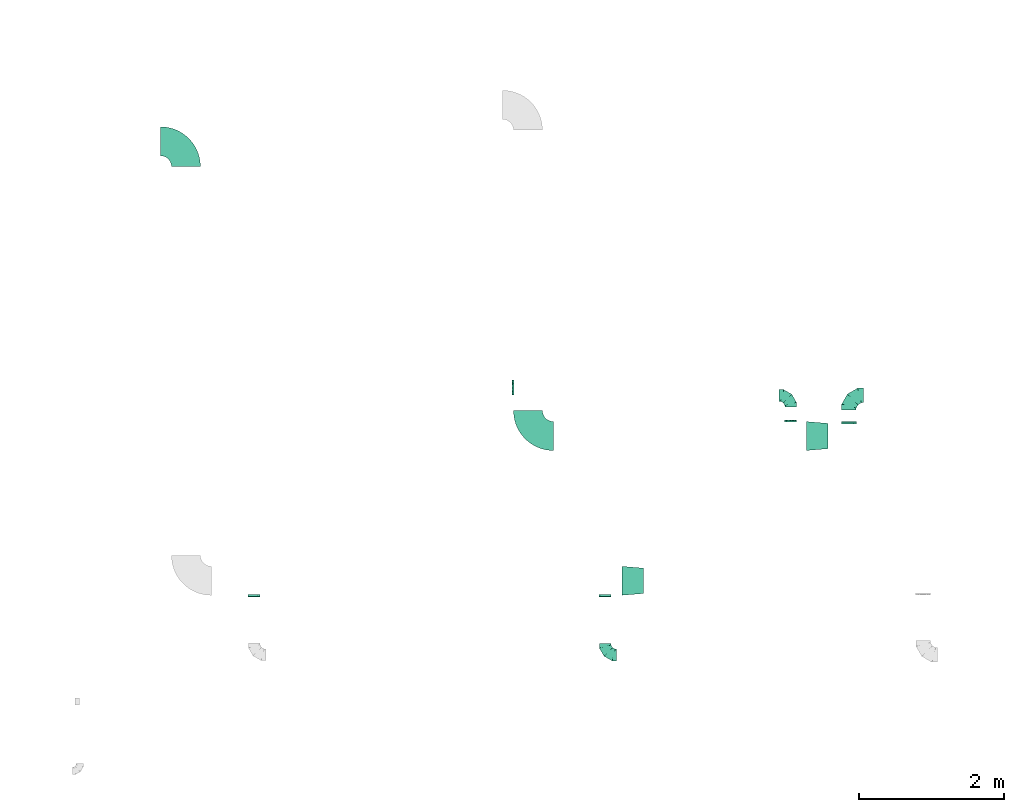
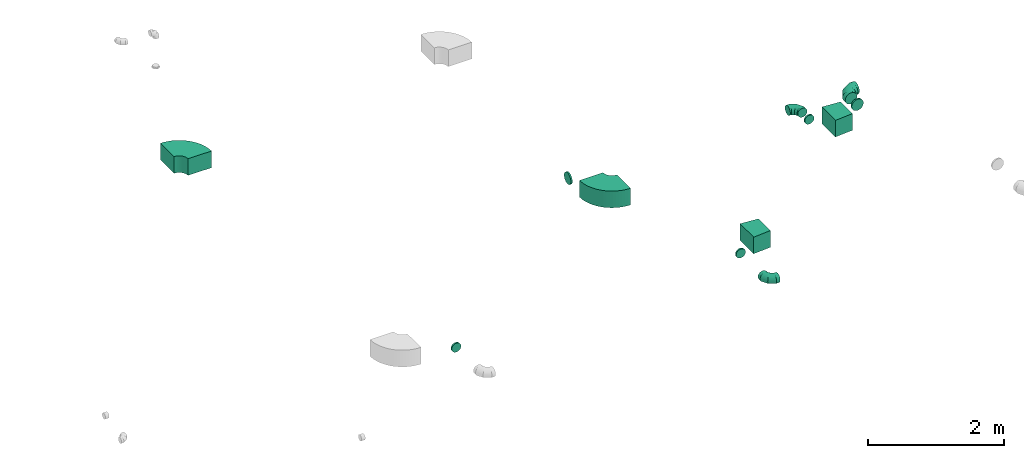
# One storey, part 15 of 32: 12 flow fittings.
"""IFC2X3 building model written with IfcOpenShell, lengths in millimetres."""

import ifcopenshell
import ifcopenshell.guid

model = None  # the IFC model being written
_history = None  # IfcOwnerHistory: only IFC2X3 demands one
_inside = {}  # id of a spatial element -> (the spatial element, [elements in it])
_under = {}  # id of a project, library or spatial element -> (it, [spatial elements below it])
_declared = {}  # id of a project -> (the project, [libraries it declares])
_typed = {}  # id of a type object -> (the type object, [elements of that type])
_made_of = {}  # id of a material, layer set ... -> (it, [elements and type objects made of it])


def new_model(schema):
    """Start an empty IFC model of exactly this schema.

    Asked for "IFC4X3", IfcOpenShell would pick the latest addendum, in which some entities
    have other attributes; the version numbers below select the first issue.
    IFC2X3 requires an IfcOwnerHistory on every rooted entity: one is made here for all.
    """
    global model, _history
    if schema == "IFC4X3":
        model = ifcopenshell.file(schema_version=(4, 3, 0, 0))
    else:
        model = ifcopenshell.file(schema=schema)
    _inside.clear()
    _under.clear()
    _declared.clear()
    _typed.clear()
    _made_of.clear()
    _history = None
    if model.schema == "IFC2X3":
        org = make("IfcOrganization", Name="unknown")
        user = make(
            "IfcPersonAndOrganization",
            ThePerson=make("IfcPerson", FamilyName="unknown"),
            TheOrganization=org,
        )
        app = make(
            "IfcApplication",
            ApplicationDeveloper=org,
            Version="unknown",
            ApplicationFullName="unknown",
            ApplicationIdentifier="unknown",
        )
        _history = make(
            "IfcOwnerHistory",
            OwningUser=user,
            OwningApplication=app,
            ChangeAction="ADDED",
            CreationDate=0,
        )
    return model


def make(cls, **values):
    """One entity of the class cls with the attributes given. An attribute that is None is left unset."""
    return model.create_entity(
        cls, **{name: value for name, value in values.items() if value is not None}
    )


def entity(cls, *values):
    """Any entity or typed value of the class cls, its attributes in the order of the schema. None: left unset."""
    e = model.create_entity(cls)
    for i, value in enumerate(values):
        if value is not None:
            e[i] = value
    return e


def rooted(cls, **values):
    """An entity with a GlobalId (a new one), such as an element, a storey or a relation."""
    return make(cls, GlobalId=ifcopenshell.guid.new(), OwnerHistory=_history, **values)


def si_unit(unit_type, name, prefix=None):
    """IfcSIUnit, for example si_unit("LENGTHUNIT", "METRE", prefix="MILLI")."""
    return make("IfcSIUnit", UnitType=unit_type, Prefix=prefix, Name=name)


def converted_unit(unit_type, name, factor, base, dimensions=None, offset=None):
    """IfcConversionBasedUnit, such as the inch: factor (a typed value) times the base unit."""
    return make(
        "IfcConversionBasedUnit"
        if offset is None
        else "IfcConversionBasedUnitWithOffset",
        ConversionOffset=offset,
        Dimensions=None
        if dimensions is None
        else entity("IfcDimensionalExponents", *dimensions),
        UnitType=unit_type,
        Name=name,
        ConversionFactor=make(
            "IfcMeasureWithUnit", ValueComponent=factor, UnitComponent=base
        ),
    )


def derived_unit(unit_type, elements):
    """IfcDerivedUnit: a product of units, each with its exponent."""
    return make(
        "IfcDerivedUnit",
        Elements=[
            make("IfcDerivedUnitElement", Unit=unit, Exponent=power)
            for unit, power in elements
        ],
        UnitType=unit_type,
    )


def assignment(units):
    """IfcUnitAssignment: the units of a project."""
    return None if units is None else make("IfcUnitAssignment", Units=units)


def point(xyz):
    """IfcCartesianPoint."""
    return None if xyz is None else make("IfcCartesianPoint", Coordinates=xyz)


def direction(xyz):
    """IfcDirection."""
    return None if xyz is None else make("IfcDirection", DirectionRatios=xyz)


def frame(location, z_axis=None, x_axis=None):
    """IfcAxis2Placement3D, a coordinate frame: its origin and axes. An axis left out is left unset."""
    return make(
        "IfcAxis2Placement3D",
        Location=point(location),
        Axis=direction(z_axis),
        RefDirection=direction(x_axis),
    )


def frame_2d(location, x_axis=None):
    """IfcAxis2Placement2D, a coordinate frame in the plane: its origin and x axis."""
    return make(
        "IfcAxis2Placement2D", Location=point(location), RefDirection=direction(x_axis)
    )


def origin():
    """The frame at (0, 0, 0) with its axes left unset."""
    return frame((0.0, 0.0, 0.0))


def place(relative_to, where):
    """IfcLocalPlacement: puts the frame where relative to a parent placement (None: the world)."""
    return make(
        "IfcLocalPlacement", PlacementRelTo=relative_to, RelativePlacement=where
    )


def context(
    kind, dimensions, precision=None, world=None, true_north=None, identifier=None
):
    """IfcGeometricRepresentationContext, for example the 3D "Model" context."""
    return make(
        "IfcGeometricRepresentationContext",
        ContextIdentifier=identifier,
        ContextType=kind,
        CoordinateSpaceDimension=dimensions,
        Precision=precision,
        WorldCoordinateSystem=world,
        TrueNorth=true_north,
    )


def subcontext(parent, identifier, kind, view, scale=None):
    """IfcGeometricRepresentationSubContext, for example "Body" below "Model"."""
    return make(
        "IfcGeometricRepresentationSubContext",
        ContextIdentifier=identifier,
        ContextType=kind,
        ParentContext=parent,
        TargetScale=scale,
        TargetView=view,
    )


def project(units=None, contexts=None):
    """IfcProject with its units and contexts."""
    return rooted(
        "IfcProject",
        Name="project",
        RepresentationContexts=contexts,
        UnitsInContext=assignment(units),
    )


def spatial(cls, under=None, at=None, **own):
    """A site, building, storey or space (cls), placed at a placement, below another one or the project."""
    s = rooted(cls, ObjectPlacement=at, **own)
    if under is not None:
        _under.setdefault(under.id(), (under, []))[1].append(s)
    return s


def polyline(points):
    """IfcPolyline through the points."""
    return make("IfcPolyline", Points=[point(p) for p in points])


def circle_curve(where, radius):
    """IfcCircle in the frame where."""
    return make("IfcCircle", Position=where, Radius=radius)


def parameter(value):
    """IfcParameterValue: where a trimmed curve begins or ends, as a parameter of its basis curve."""
    return model.create_entity("IfcParameterValue", value)


def trimmed(basis, trim1, trim2, sense, master):
    """IfcTrimmedCurve: the piece of a basis curve between two trims."""
    return make(
        "IfcTrimmedCurve",
        BasisCurve=basis,
        Trim1=trim1,
        Trim2=trim2,
        SenseAgreement=sense,
        MasterRepresentation=master,
    )


def segment(curve, same_sense, transition):
    """IfcCompositeCurveSegment."""
    return make(
        "IfcCompositeCurveSegment",
        Transition=transition,
        SameSense=same_sense,
        ParentCurve=curve,
    )


def composite_curve(segments, self_intersect=None):
    """IfcCompositeCurve: segments joined end to end."""
    return make("IfcCompositeCurve", Segments=segments, SelfIntersect=self_intersect)


def outline(outer, holes=None, kind="AREA"):
    """IfcArbitraryClosedProfileDef: a profile drawn as a closed curve; with holes, ...WithVoids."""
    if holes is None:
        return make("IfcArbitraryClosedProfileDef", ProfileType=kind, OuterCurve=outer)
    return make(
        "IfcArbitraryProfileDefWithVoids",
        ProfileType=kind,
        OuterCurve=outer,
        InnerCurves=holes,
    )


def extrude(swept, where, along, depth):
    """IfcExtrudedAreaSolid: the profile swept, set in the frame where, extruded along a direction by depth."""
    return make(
        "IfcExtrudedAreaSolid",
        SweptArea=swept,
        Position=where,
        ExtrudedDirection=direction(along),
        Depth=depth,
    )


def faces_of(points, faces, orient=None, outer=None):
    """IfcFace entities. A face is a list of loops; a loop is a list of indices into points, from 0.

    orient and outer hold one flag for each loop. By default every Orientation is true, the
    first loop of a face is its IfcFaceOuterBound and the others are IfcFaceBound.
    """
    made = []
    for i, loops in enumerate(faces):
        bounds = []
        for j, loop in enumerate(loops):
            is_outer = j == 0 if outer is None else outer[i][j]
            bounds.append(
                make(
                    "IfcFaceOuterBound" if is_outer else "IfcFaceBound",
                    Bound=make("IfcPolyLoop", Polygon=[points[k] for k in loop]),
                    Orientation=True if orient is None else orient[i][j],
                )
            )
        made.append(make("IfcFace", Bounds=bounds))
    return made


def faceted_brep(points, faces, orient=None, outer=None, voids=None):
    """IfcFacetedBrep: a solid bounded by flat faces; with voids (closed shells), ...WithVoids."""
    shared = [point(p) for p in points]
    hull = make("IfcClosedShell", CfsFaces=faces_of(shared, faces, orient, outer))
    if voids is None:
        return make("IfcFacetedBrep", Outer=hull)
    return make(
        "IfcFacetedBrepWithVoids",
        Outer=hull,
        Voids=[
            make(cls, CfsFaces=faces_of(shared, fs, o, b)) for cls, fs, o, b in voids
        ],
    )


def shape(context_of_items, identifier, shape_type, items):
    """IfcShapeRepresentation: the items that make up one representation, for example the "Body"."""
    return make(
        "IfcShapeRepresentation",
        ContextOfItems=context_of_items,
        RepresentationIdentifier=identifier,
        RepresentationType=shape_type,
        Items=items,
    )


def source(mapping_origin, context_of_items, identifier, shape_type, items):
    """IfcRepresentationMap: a shape defined once, which mapped items show again and again."""
    return make(
        "IfcRepresentationMap",
        MappingOrigin=mapping_origin,
        MappedRepresentation=shape(context_of_items, identifier, shape_type, items),
    )


def transform(
    local_origin,
    x_axis=None,
    y_axis=None,
    z_axis=None,
    scale=None,
    scale2=None,
    scale3=None,
    uniform=True,
):
    """IfcCartesianTransformationOperator3D, or its non-uniform kind. x_axis, y_axis, z_axis: its Axis1, 2, 3."""
    if uniform:
        return make(
            "IfcCartesianTransformationOperator3D",
            Axis1=direction(x_axis),
            Axis2=direction(y_axis),
            LocalOrigin=point(local_origin),
            Scale=scale,
            Axis3=direction(z_axis),
        )
    return make(
        "IfcCartesianTransformationOperator3DnonUniform",
        Axis1=direction(x_axis),
        Axis2=direction(y_axis),
        LocalOrigin=point(local_origin),
        Scale=scale,
        Axis3=direction(z_axis),
        Scale2=scale2,
        Scale3=scale3,
    )


def mapped(mapping_source, mapping_target):
    """IfcMappedItem: shows the shape of a source again, moved by a transform."""
    return make(
        "IfcMappedItem", MappingSource=mapping_source, MappingTarget=mapping_target
    )


def material(Name=None, Category=None):
    """IfcMaterial."""
    return make("IfcMaterial", Name=Name, Category=Category)


def made_of(thing, what):
    """Note that an element or type object is made of a material, layer set ...; save() writes the relation."""
    if what is not None:
        _made_of.setdefault(what.id(), (what, []))[1].append(thing)
    return thing


def type_object(cls, material=None, **own):
    """A type object (cls), such as IfcWallType, which elements share."""
    return made_of(rooted(cls, **own), material)


def type_shapes(of_type, sources):
    """Give a type object the sources (RepresentationMaps) that its elements show as mapped items."""
    of_type.RepresentationMaps = sources


def element(
    cls,
    number,
    at=None,
    inside=None,
    cuts=None,
    type_object=None,
    material=None,
    context=None,
    identifier="Body",
    shape_type=None,
    held_by="IfcProductDefinitionShape",
    body=None,
    shapes=None,
    **own,
):
    """One element of the class cls, such as IfcWall. Its Tag is "e" and its number.

    at: its placement. inside: the storey or other place that contains it. cuts: it is an
    opening in that element (IfcRelVoidsElement). A single representation is given by context,
    identifier, shape_type and body (its items); several are given by shapes. held_by: the class
    of the entity that holds the representations. save() writes the other relations.
    """
    e = rooted(cls, Tag="e%d" % number, ObjectPlacement=at, **own)
    if body is not None:
        shapes = [shape(context, identifier, shape_type, body)]
    if shapes is not None:
        e.Representation = make(held_by, Representations=shapes)
    if inside is not None:
        _inside.setdefault(inside.id(), (inside, []))[1].append(e)
    if cuts is not None:
        rooted(
            "IfcRelVoidsElement", RelatingBuildingElement=cuts, RelatedOpeningElement=e
        )
    if type_object is not None:
        _typed.setdefault(type_object.id(), (type_object, []))[1].append(e)
    return made_of(e, material)


def aggregate(whole, parts):
    """IfcRelAggregates: a whole, such as a stair, and the parts it consists of."""
    return rooted("IfcRelAggregates", RelatingObject=whole, RelatedObjects=parts)


def save(model, path):
    """Write the relations noted so far, then the file.

    IfcRelAggregates (storeys below a building ...), IfcRelContainedInSpatialStructure (elements
    in a storey), IfcRelDefinesByType, IfcRelAssociatesMaterial and IfcRelDeclares: one each for
    every whole, place, type object, material and project.
    """
    for whole, parts in _under.values():
        aggregate(whole, parts)
    for where, things in _inside.values():
        rooted(
            "IfcRelContainedInSpatialStructure",
            RelatedElements=things,
            RelatingStructure=where,
        )
    for kind, things in _typed.values():
        rooted("IfcRelDefinesByType", RelatedObjects=things, RelatingType=kind)
    for what, things in _made_of.values():
        rooted("IfcRelAssociatesMaterial", RelatedObjects=things, RelatingMaterial=what)
    for by, libraries in _declared.values():
        rooted("IfcRelDeclares", RelatingContext=by, RelatedDefinitions=libraries)
    model.write(path)


model = new_model("IFC2X3")

# Units and contexts
model_context = context("Model", 3, precision=0.01, world=origin(), true_north=direction((6.12303176911189e-17, 1.0)))
body_context = subcontext(model_context, "Body", "Model", "MODEL_VIEW")
ifc_project = project(units=[si_unit("LENGTHUNIT", "METRE", prefix="MILLI"), si_unit("AREAUNIT", "SQUARE_METRE"), si_unit("VOLUMEUNIT", "CUBIC_METRE"), converted_unit("PLANEANGLEUNIT", "DEGREE", entity("IfcRatioMeasure", 0.0174532925199433), si_unit("PLANEANGLEUNIT", "RADIAN"), dimensions=[0, 0, 0, 0, 0, 0, 0]), si_unit("MASSUNIT", "GRAM", prefix="KILO"), derived_unit("MASSDENSITYUNIT", [(si_unit("MASSUNIT", "GRAM", prefix="KILO"), 1), (si_unit("LENGTHUNIT", "METRE"), -3)]), derived_unit("MOMENTOFINERTIAUNIT", [(si_unit("LENGTHUNIT", "METRE"), 4)]), si_unit("TIMEUNIT", "SECOND"), si_unit("FREQUENCYUNIT", "HERTZ"), si_unit("THERMODYNAMICTEMPERATUREUNIT", "DEGREE_CELSIUS"), derived_unit("THERMALTRANSMITTANCEUNIT", [(si_unit("MASSUNIT", "GRAM", prefix="KILO"), 1), (si_unit("THERMODYNAMICTEMPERATUREUNIT", "KELVIN"), -1), (si_unit("TIMEUNIT", "SECOND"), -3)]), derived_unit("VOLUMETRICFLOWRATEUNIT", [(si_unit("LENGTHUNIT", "METRE"), 3), (si_unit("TIMEUNIT", "SECOND"), -1)]), derived_unit("MASSFLOWRATEUNIT", [(si_unit("MASSUNIT", "GRAM", prefix="KILO"), 1), (si_unit("TIMEUNIT", "SECOND"), -1)]), derived_unit("ROTATIONALFREQUENCYUNIT", [(si_unit("TIMEUNIT", "SECOND"), -1)]), si_unit("ELECTRICCURRENTUNIT", "AMPERE"), si_unit("ELECTRICVOLTAGEUNIT", "VOLT"), si_unit("POWERUNIT", "WATT"), si_unit("FORCEUNIT", "NEWTON", prefix="KILO"), si_unit("ILLUMINANCEUNIT", "LUX"), si_unit("LUMINOUSFLUXUNIT", "LUMEN"), si_unit("LUMINOUSINTENSITYUNIT", "CANDELA"), derived_unit("USERDEFINED", [(si_unit("MASSUNIT", "GRAM", prefix="KILO"), -1), (si_unit("LENGTHUNIT", "METRE"), -2), (si_unit("TIMEUNIT", "SECOND"), 3), (si_unit("LUMINOUSFLUXUNIT", "LUMEN"), 1)]), derived_unit("LINEARVELOCITYUNIT", [(si_unit("LENGTHUNIT", "METRE"), 1), (si_unit("TIMEUNIT", "SECOND"), -1)]), si_unit("PRESSUREUNIT", "PASCAL"), derived_unit("USERDEFINED", [(si_unit("LENGTHUNIT", "METRE"), -2), (si_unit("MASSUNIT", "GRAM", prefix="KILO"), 1), (si_unit("TIMEUNIT", "SECOND"), -2)]), derived_unit("LINEARFORCEUNIT", [(si_unit("MASSUNIT", "GRAM", prefix="KILO"), 1), (si_unit("LENGTHUNIT", "METRE"), 1), (si_unit("TIMEUNIT", "SECOND"), -2), (si_unit("LENGTHUNIT", "METRE"), -1)]), derived_unit("PLANARFORCEUNIT", [(si_unit("MASSUNIT", "GRAM", prefix="KILO"), 1), (si_unit("LENGTHUNIT", "METRE"), 1), (si_unit("TIMEUNIT", "SECOND"), -2), (si_unit("LENGTHUNIT", "METRE"), -2)])], contexts=[model_context])

# Site, building, storey
site_placement = place(None, origin())
site = spatial("IfcSite", under=ifc_project, at=site_placement, CompositionType="ELEMENT")
building_placement = place(site_placement, origin())
building = spatial("IfcBuilding", under=site, at=building_placement, CompositionType="ELEMENT")
storey_placement = place(building_placement, frame((0.0, 0.0, 8100.0)))
storey = spatial("IfcBuildingStorey", under=building, at=storey_placement, CompositionType="ELEMENT", Elevation=8100.0)

# Flow fittings
ifc_material = material()
duct_fitting_type_1 = type_object("IfcDuctFittingType", PredefinedType="NOTDEFINED", material=ifc_material)
shared_shape_1 = source(origin(), body_context, "Body", "SweptSolid", [
    extrude(outline(polyline([(-166.09, -186.85), (134.95, -186.85), (164.01, 161.94), (-132.87, 211.77), (-166.09, -186.85)])), frame((150.0, 0.0, -150.0), z_axis=(0.0, 0.0, 1.0), x_axis=(0.99654575824488, 0.0830454798537382, 0.0)), (0.0, 0.0, 1.0), 300.0),
])
type_shapes(duct_fitting_type_1, [shared_shape_1])
for number, where in (
    (1, (48557.3, 5120.54, 3300.0)),
    (2, (46011.81, 3122.88, 3300.0)),
):
    element("IfcFlowFitting", number, at=place(storey_placement, frame(where)), inside=storey, type_object=duct_fitting_type_1, material=ifc_material, context=body_context, shape_type="MappedRepresentation", body=[
        mapped(shared_shape_1, transform((0.0, 0.0, 0.0), scale=1.0)),
    ])
duct_fitting_type_2 = type_object("IfcDuctFittingType", PredefinedType="NOTDEFINED", material=ifc_material)
shared_shape_2 = source(origin(), body_context, "Body", "Brep", [
    faceted_brep([(-160.0, 0.0, -80.0), (-160.0, -20.71, -77.27), (-160.0, -40.0, -69.28), (-160.0, -56.57, -56.57), (-160.0, -69.28, -40.0), (-160.0, -77.27, -20.71), (-160.0, -80.0, 0.0), (-160.0, -77.27, 20.71), (-160.0, -69.28, 40.0), (-160.0, -56.57, 56.57), (-160.0, -40.0, 69.28), (-160.0, -20.71, 77.27), (-160.0, 0.0, 80.0), (-160.0, 20.71, 77.27), (-160.0, 40.0, 69.28), (-160.0, 56.57, 56.57), (-160.0, 69.28, 40.0), (-160.0, 77.27, 20.71), (-160.0, 80.0, 0.0), (-160.0, 77.27, -20.71), (-160.0, 69.28, -40.0), (-160.0, 56.57, -56.57), (-160.0, 40.0, -69.28), (-160.0, 20.71, -77.27), (-122.68, 20.71, 77.27), (-127.85, 40.0, 69.28), (-117.13, 0.0, 80.0), (-132.29, 56.57, 56.57), (-137.83, 77.27, 20.71), (-138.56, 80.0, 0.0), (-135.69, 69.28, 40.0), (-135.69, 69.28, -40.0), (-132.29, 56.57, -56.57), (-137.83, 77.27, -20.71), (-122.68, 20.71, -77.27), (-117.13, 0.0, -80.0), (-127.85, 40.0, -69.28), (-111.58, -20.71, -77.27), (-106.41, -40.0, -69.28), (-101.97, -56.57, -56.57), (-98.56, -69.28, -40.0), (-96.42, -77.27, -20.71), (-95.69, -80.0, 0.0), (-96.42, -77.27, 20.71), (-98.56, -69.28, 40.0), (-101.97, -56.57, 56.57), (-106.41, -40.0, 69.28), (-111.58, -20.71, 77.27), (-58.03, 58.03, 77.27), (-72.15, 72.15, 69.28), (-42.87, 42.87, 80.0), (-84.28, 84.28, 56.57), (-93.59, 93.59, 40.0), (-99.44, 99.44, 20.71), (-101.44, 101.44, 0.0), (-99.44, 99.44, -20.71), (-93.59, 93.59, -40.0), (-84.28, 84.28, -56.57), (-58.03, 58.03, -77.27), (-42.87, 42.87, -80.0), (-72.15, 72.15, -69.28), (-27.71, 27.71, -77.27), (-13.59, 13.59, -69.28), (-1.46, 1.46, -56.57), (7.85, -7.85, -40.0), (13.7, -13.7, -20.71), (15.69, -15.69, 0.0), (13.7, -13.7, 20.71), (7.85, -7.85, 40.0), (-1.46, 1.46, 56.57), (-13.59, 13.59, 69.28), (-27.71, 27.71, 77.27), (-20.71, 122.68, 77.27), (-40.0, 127.85, 69.28), (0.0, 117.13, 80.0), (-56.57, 132.29, 56.57), (-69.28, 135.69, 40.0), (-77.27, 137.83, 20.71), (-80.0, 138.56, 0.0), (-77.27, 137.83, -20.71), (-69.28, 135.69, -40.0), (-56.57, 132.29, -56.57), (-20.71, 122.68, -77.27), (0.0, 117.13, -80.0), (-40.0, 127.85, -69.28), (20.71, 111.58, -77.27), (40.0, 106.41, -69.28), (56.57, 101.97, -56.57), (69.28, 98.56, -40.0), (77.27, 96.42, -20.71), (80.0, 95.69, 0.0), (77.27, 96.42, 20.71), (69.28, 98.56, 40.0), (56.57, 101.97, 56.57), (40.0, 106.41, 69.28), (20.71, 111.58, 77.27), (-20.71, 160.0, -77.27), (-40.0, 160.0, -69.28), (-56.57, 160.0, -56.57), (-69.28, 160.0, -40.0), (-77.27, 160.0, -20.71), (-80.0, 160.0, 0.0), (-77.27, 160.0, 20.71), (-69.28, 160.0, 40.0), (-56.57, 160.0, 56.57), (-40.0, 160.0, 69.28), (-20.71, 160.0, 77.27), (0.0, 160.0, 80.0), (20.71, 160.0, 77.27), (40.0, 160.0, 69.28), (56.57, 160.0, 56.57), (69.28, 160.0, 40.0), (77.27, 160.0, 20.71), (80.0, 160.0, 0.0), (77.27, 160.0, -20.71), (69.28, 160.0, -40.0), (56.57, 160.0, -56.57), (40.0, 160.0, -69.28), (20.71, 160.0, -77.27), (0.0, 160.0, -80.0)], [[[0, 1, 2, 3, 4, 5, 6, 7, 8, 9, 10, 11, 12, 13, 14, 15, 16, 17, 18, 19, 20, 21, 22, 23]], [[24, 25, 14, 13]], [[26, 24, 13, 12]], [[14, 25, 27, 15]], [[28, 29, 18, 17]], [[30, 28, 17, 16]], [[15, 27, 30, 16]], [[20, 31, 32, 21]], [[33, 31, 20, 19]], [[18, 29, 33, 19]], [[34, 35, 0, 23]], [[36, 34, 23, 22]], [[32, 36, 22, 21]], [[1, 0, 35, 37]], [[2, 1, 37, 38]], [[3, 2, 38, 39]], [[5, 4, 40, 41]], [[6, 5, 41, 42]], [[39, 40, 4, 3]], [[6, 42, 43, 7]], [[7, 43, 44, 8]], [[8, 44, 45, 9]], [[9, 45, 46, 10]], [[10, 46, 47, 11]], [[26, 12, 11, 47]], [[48, 49, 25, 24]], [[50, 48, 24, 26]], [[27, 25, 49, 51]], [[52, 53, 28, 30]], [[51, 52, 30, 27]], [[29, 28, 53, 54]], [[55, 56, 31, 33]], [[54, 55, 33, 29]], [[32, 31, 56, 57]], [[58, 59, 35, 34]], [[60, 58, 34, 36]], [[57, 60, 36, 32]], [[37, 35, 59, 61]], [[38, 37, 61, 62]], [[39, 38, 62, 63]], [[41, 40, 64, 65]], [[42, 41, 65, 66]], [[63, 64, 40, 39]], [[43, 42, 66, 67]], [[44, 43, 67, 68]], [[68, 69, 45, 44]], [[46, 45, 69, 70]], [[47, 46, 70, 71]], [[26, 47, 71, 50]], [[72, 73, 49, 48]], [[74, 72, 48, 50]], [[51, 49, 73, 75]], [[76, 77, 53, 52]], [[75, 76, 52, 51]], [[54, 53, 77, 78]], [[79, 80, 56, 55]], [[78, 79, 55, 54]], [[57, 56, 80, 81]], [[82, 83, 59, 58]], [[84, 82, 58, 60]], [[81, 84, 60, 57]], [[61, 59, 83, 85]], [[62, 61, 85, 86]], [[63, 62, 86, 87]], [[65, 64, 88, 89]], [[66, 65, 89, 90]], [[87, 88, 64, 63]], [[67, 66, 90, 91]], [[68, 67, 91, 92]], [[92, 93, 69, 68]], [[70, 69, 93, 94]], [[71, 70, 94, 95]], [[50, 71, 95, 74]], [[96, 97, 98, 99, 100, 101, 102, 103, 104, 105, 106, 107, 108, 109, 110, 111, 112, 113, 114, 115, 116, 117, 118, 119]], [[72, 74, 107, 106]], [[73, 72, 106, 105]], [[75, 73, 105, 104]], [[77, 76, 103, 102]], [[78, 77, 102, 101]], [[75, 104, 103, 76]], [[78, 101, 100, 79]], [[79, 100, 99, 80]], [[80, 99, 98, 81]], [[84, 97, 96, 82]], [[82, 96, 119, 83]], [[84, 81, 98, 97]], [[118, 117, 86, 85]], [[119, 118, 85, 83]], [[116, 87, 86, 117]], [[88, 115, 114, 89]], [[89, 114, 113, 90]], [[115, 88, 87, 116]], [[112, 111, 92, 91]], [[113, 112, 91, 90]], [[111, 110, 93, 92]], [[95, 94, 109, 108]], [[74, 95, 108, 107]], [[110, 109, 94, 93]]]),
])
type_shapes(duct_fitting_type_2, [shared_shape_2])
for number, where, z_axis, x_axis in (
    (3, (48341.3, 5680.54, 3300.0), (0.0, 0.0, 1.0), (0.0, 1.0, 0.0)),
    (4, (45781.48, 2099.16, 3250.0), (0.0, 0.0, 1.0), (0.0, -1.0, 0.0)),
):
    element("IfcFlowFitting", number, at=place(storey_placement, frame(where, z_axis=z_axis, x_axis=x_axis)), inside=storey, type_object=duct_fitting_type_2, material=ifc_material, context=body_context, shape_type="MappedRepresentation", body=[
        mapped(shared_shape_2, transform((0.0, 0.0, 0.0), scale=1.0)),
    ])
duct_fitting_type_3 = type_object("IfcDuctFittingType", PredefinedType="NOTDEFINED", material=ifc_material)
shared_shape_3 = source(origin(), body_context, "Body", "Brep", [
    faceted_brep([(-200.0, 0.0, -100.0), (-200.0, -25.88, -96.59), (-200.0, -50.0, -86.6), (-200.0, -70.71, -70.71), (-200.0, -86.6, -50.0), (-200.0, -96.59, -25.88), (-200.0, -100.0, 0.0), (-200.0, -96.59, 25.88), (-200.0, -86.6, 50.0), (-200.0, -70.71, 70.71), (-200.0, -50.0, 86.6), (-200.0, -25.88, 96.59), (-200.0, 0.0, 100.0), (-200.0, 25.88, 96.59), (-200.0, 50.0, 86.6), (-200.0, 70.71, 70.71), (-200.0, 86.6, 50.0), (-200.0, 96.59, 25.88), (-200.0, 100.0, 0.0), (-200.0, 96.59, -25.88), (-200.0, 86.6, -50.0), (-200.0, 70.71, -70.71), (-200.0, 50.0, -86.6), (-200.0, 25.88, -96.59), (-153.35, 25.88, 96.59), (-159.81, 50.0, 86.6), (-146.41, 0.0, 100.0), (-165.36, 70.71, 70.71), (-172.29, 96.59, 25.88), (-173.21, 100.0, 0.0), (-169.62, 86.6, 50.0), (-169.62, 86.6, -50.0), (-165.36, 70.71, -70.71), (-172.29, 96.59, -25.88), (-153.35, 25.88, -96.59), (-146.41, 0.0, -100.0), (-159.81, 50.0, -86.6), (-139.48, -25.88, -96.59), (-133.01, -50.0, -86.6), (-127.46, -70.71, -70.71), (-123.21, -86.6, -50.0), (-120.53, -96.59, -25.88), (-119.62, -100.0, 0.0), (-120.53, -96.59, 25.88), (-123.21, -86.6, 50.0), (-127.46, -70.71, 70.71), (-133.01, -50.0, 86.6), (-139.48, -25.88, 96.59), (-72.54, 72.54, 96.59), (-90.19, 90.19, 86.6), (-53.59, 53.59, 100.0), (-105.35, 105.35, 70.71), (-116.99, 116.99, 50.0), (-124.3, 124.3, 25.88), (-126.79, 126.79, 0.0), (-124.3, 124.3, -25.88), (-116.99, 116.99, -50.0), (-105.35, 105.35, -70.71), (-72.54, 72.54, -96.59), (-53.59, 53.59, -100.0), (-90.19, 90.19, -86.6), (-34.64, 34.64, -96.59), (-16.99, 16.99, -86.6), (-1.83, 1.83, -70.71), (9.81, -9.81, -50.0), (17.12, -17.12, -25.88), (19.62, -19.62, 0.0), (17.12, -17.12, 25.88), (9.81, -9.81, 50.0), (-1.83, 1.83, 70.71), (-16.99, 16.99, 86.6), (-34.64, 34.64, 96.59), (-25.88, 153.35, 96.59), (-50.0, 159.81, 86.6), (0.0, 146.41, 100.0), (-70.71, 165.36, 70.71), (-86.6, 169.62, 50.0), (-96.59, 172.29, 25.88), (-100.0, 173.21, 0.0), (-96.59, 172.29, -25.88), (-86.6, 169.62, -50.0), (-70.71, 165.36, -70.71), (-25.88, 153.35, -96.59), (0.0, 146.41, -100.0), (-50.0, 159.81, -86.6), (25.88, 139.48, -96.59), (50.0, 133.01, -86.6), (70.71, 127.46, -70.71), (86.6, 123.21, -50.0), (96.59, 120.53, -25.88), (100.0, 119.62, 0.0), (96.59, 120.53, 25.88), (86.6, 123.21, 50.0), (70.71, 127.46, 70.71), (50.0, 133.01, 86.6), (25.88, 139.48, 96.59), (-25.88, 200.0, -96.59), (-50.0, 200.0, -86.6), (-70.71, 200.0, -70.71), (-86.6, 200.0, -50.0), (-96.59, 200.0, -25.88), (-100.0, 200.0, 0.0), (-96.59, 200.0, 25.88), (-86.6, 200.0, 50.0), (-70.71, 200.0, 70.71), (-50.0, 200.0, 86.6), (-25.88, 200.0, 96.59), (0.0, 200.0, 100.0), (25.88, 200.0, 96.59), (50.0, 200.0, 86.6), (70.71, 200.0, 70.71), (86.6, 200.0, 50.0), (96.59, 200.0, 25.88), (100.0, 200.0, 0.0), (96.59, 200.0, -25.88), (86.6, 200.0, -50.0), (70.71, 200.0, -70.71), (50.0, 200.0, -86.6), (25.88, 200.0, -96.59), (0.0, 200.0, -100.0)], [[[0, 1, 2, 3, 4, 5, 6, 7, 8, 9, 10, 11, 12, 13, 14, 15, 16, 17, 18, 19, 20, 21, 22, 23]], [[24, 25, 14, 13]], [[26, 24, 13, 12]], [[14, 25, 27, 15]], [[28, 29, 18, 17]], [[30, 28, 17, 16]], [[15, 27, 30, 16]], [[20, 31, 32, 21]], [[33, 31, 20, 19]], [[18, 29, 33, 19]], [[34, 35, 0, 23]], [[36, 34, 23, 22]], [[32, 36, 22, 21]], [[1, 0, 35, 37]], [[2, 1, 37, 38]], [[38, 39, 3, 2]], [[5, 4, 40, 41]], [[6, 5, 41, 42]], [[39, 40, 4, 3]], [[6, 42, 43, 7]], [[7, 43, 44, 8]], [[8, 44, 45, 9]], [[9, 45, 46, 10]], [[10, 46, 47, 11]], [[26, 12, 11, 47]], [[48, 49, 25, 24]], [[50, 48, 24, 26]], [[27, 25, 49, 51]], [[52, 53, 28, 30]], [[51, 52, 30, 27]], [[29, 28, 53, 54]], [[55, 56, 31, 33]], [[54, 55, 33, 29]], [[32, 31, 56, 57]], [[58, 59, 35, 34]], [[60, 58, 34, 36]], [[57, 60, 36, 32]], [[37, 35, 59, 61]], [[38, 37, 61, 62]], [[39, 38, 62, 63]], [[41, 40, 64, 65]], [[42, 41, 65, 66]], [[63, 64, 40, 39]], [[43, 42, 66, 67]], [[44, 43, 67, 68]], [[68, 69, 45, 44]], [[46, 45, 69, 70]], [[47, 46, 70, 71]], [[26, 47, 71, 50]], [[72, 73, 49, 48]], [[74, 72, 48, 50]], [[51, 49, 73, 75]], [[76, 77, 53, 52]], [[75, 76, 52, 51]], [[54, 53, 77, 78]], [[79, 80, 56, 55]], [[78, 79, 55, 54]], [[57, 56, 80, 81]], [[82, 83, 59, 58]], [[84, 82, 58, 60]], [[81, 84, 60, 57]], [[61, 59, 83, 85]], [[62, 61, 85, 86]], [[63, 62, 86, 87]], [[65, 64, 88, 89]], [[66, 65, 89, 90]], [[87, 88, 64, 63]], [[67, 66, 90, 91]], [[68, 67, 91, 92]], [[92, 93, 69, 68]], [[70, 69, 93, 94]], [[71, 70, 94, 95]], [[50, 71, 95, 74]], [[96, 97, 98, 99, 100, 101, 102, 103, 104, 105, 106, 107, 108, 109, 110, 111, 112, 113, 114, 115, 116, 117, 118, 119]], [[72, 74, 107, 106]], [[73, 72, 106, 105]], [[75, 73, 105, 104]], [[102, 101, 78, 77]], [[103, 102, 77, 76]], [[75, 104, 103, 76]], [[78, 101, 100, 79]], [[79, 100, 99, 80]], [[80, 99, 98, 81]], [[84, 97, 96, 82]], [[82, 96, 119, 83]], [[84, 81, 98, 97]], [[118, 117, 86, 85]], [[119, 118, 85, 83]], [[116, 87, 86, 117]], [[88, 115, 114, 89]], [[89, 114, 113, 90]], [[115, 88, 87, 116]], [[91, 90, 113, 112]], [[92, 91, 112, 111]], [[111, 110, 93, 92]], [[95, 94, 109, 108]], [[74, 95, 108, 107]], [[110, 109, 94, 93]]]),
])
type_shapes(duct_fitting_type_3, [shared_shape_3])
flow_fitting_1_placement = place(storey_placement, frame((49145.82, 5680.54, 3300.0), z_axis=(0.0, 0.0, 1.0), x_axis=(-1.0, 0.0, 0.0)))
element("IfcFlowFitting", 5, at=flow_fitting_1_placement, inside=storey, type_object=duct_fitting_type_3, material=ifc_material, context=body_context, shape_type="MappedRepresentation", body=[
    mapped(shared_shape_3, transform((0.0, 0.0, 0.0), scale=1.0)),
])
duct_fitting_type_4 = type_object("IfcDuctFittingType", PredefinedType="NOTDEFINED", material=ifc_material)
shared_shape_4 = source(origin(), body_context, "Body", "Brep", [
    faceted_brep([(20.0, 0.0, -80.0), (20.0, 20.71, -77.27), (20.0, 40.0, -69.28), (20.0, 56.57, -56.57), (20.0, 69.28, -40.0), (20.0, 77.27, -20.71), (20.0, 80.0, 0.0), (20.0, 77.27, 20.71), (20.0, 69.28, 40.0), (20.0, 56.57, 56.57), (20.0, 40.0, 69.28), (20.0, 20.71, 77.27), (20.0, 0.0, 80.0), (20.0, -20.71, 77.27), (20.0, -40.0, 69.28), (20.0, -56.57, 56.57), (20.0, -69.28, 40.0), (20.0, -77.27, 20.71), (20.0, -80.0, 0.0), (20.0, -77.27, -20.71), (20.0, -69.28, -40.0), (20.0, -56.57, -56.57), (20.0, -40.0, -69.28), (20.0, -20.71, -77.27), (0.0, 0.0, 80.0), (-6.1, 0.0, 80.0), (-6.1, -20.71, 77.27), (0.0, -20.71, 77.27), (-6.1, -40.0, 69.28), (0.0, -40.0, 69.28), (0.0, -56.57, 56.57), (-6.1, -56.57, 56.57), (0.0, -69.28, 40.0), (-6.1, -69.28, 40.0), (-6.1, -77.27, 20.71), (0.0, -77.27, 20.71), (-6.1, -80.0, 0.0), (0.0, -80.0, 0.0), (-6.1, -77.27, -20.71), (0.0, -77.27, -20.71), (-6.1, -69.28, -40.0), (0.0, -69.28, -40.0), (0.0, -56.57, -56.57), (-6.1, -56.57, -56.57), (0.0, -40.0, -69.28), (-6.1, -40.0, -69.28), (-6.1, -20.71, -77.27), (0.0, -20.71, -77.27), (-6.1, 0.0, -80.0), (0.0, 0.0, -80.0), (-6.1, 20.71, -77.27), (0.0, 20.71, -77.27), (-6.1, 40.0, -69.28), (0.0, 40.0, -69.28), (0.0, 56.57, -56.57), (-6.1, 56.57, -56.57), (0.0, 69.28, -40.0), (-6.1, 69.28, -40.0), (-6.1, 77.27, -20.71), (0.0, 77.27, -20.71), (-6.1, 80.0, 0.0), (0.0, 80.0, 0.0), (-6.1, 77.27, 20.71), (0.0, 77.27, 20.71), (-6.1, 69.28, 40.0), (0.0, 69.28, 40.0), (0.0, 56.57, 56.57), (-6.1, 56.57, 56.57), (0.0, 40.0, 69.28), (-6.1, 40.0, 69.28), (-6.1, 20.71, 77.27), (0.0, 20.71, 77.27)], [[[0, 1, 2, 3, 4, 5, 6, 7, 8, 9, 10, 11, 12, 13, 14, 15, 16, 17, 18, 19, 20, 21, 22, 23]], [[13, 12, 24, 25, 26, 27]], [[14, 13, 27, 26, 28, 29]], [[30, 15, 14, 29, 28, 31]], [[17, 16, 32, 33, 34, 35]], [[18, 17, 35, 34, 36, 37]], [[32, 16, 15, 30, 31, 33]], [[19, 18, 37, 36, 38, 39]], [[20, 19, 39, 38, 40, 41]], [[42, 21, 20, 41, 40, 43]], [[23, 22, 44, 45, 46, 47]], [[0, 23, 47, 46, 48, 49]], [[44, 22, 21, 42, 43, 45]], [[1, 0, 49, 48, 50, 51]], [[2, 1, 51, 50, 52, 53]], [[54, 3, 2, 53, 52, 55]], [[5, 4, 56, 57, 58, 59]], [[6, 5, 59, 58, 60, 61]], [[56, 4, 3, 54, 55, 57]], [[7, 6, 61, 60, 62, 63]], [[8, 7, 63, 62, 64, 65]], [[66, 9, 8, 65, 64, 67]], [[11, 10, 68, 69, 70, 71]], [[12, 11, 71, 70, 25, 24]], [[68, 10, 9, 66, 67, 69]], [[46, 45, 43, 40, 38, 36, 34, 33, 31, 28, 26, 25, 70, 69, 67, 64, 62, 60, 58, 57, 55, 52, 50, 48]]]),
])
type_shapes(duct_fitting_type_4, [shared_shape_4])
flow_fitting_2_placement = place(storey_placement, frame((48341.3, 5320.54, 3300.0), z_axis=(0.0, 0.0, -1.0), x_axis=(0.0, 1.0, 0.0)))
element("IfcFlowFitting", 6, at=flow_fitting_2_placement, inside=storey, type_object=duct_fitting_type_4, material=ifc_material, context=body_context, shape_type="MappedRepresentation", body=[
    mapped(shared_shape_4, transform((0.0, 0.0, 0.0), scale=1.0)),
])
duct_fitting_type_5 = type_object("IfcDuctFittingType", PredefinedType="NOTDEFINED", material=ifc_material)
shared_shape_5 = source(origin(), body_context, "Body", "Brep", [
    faceted_brep([(20.0, 25.88, -96.59), (20.0, 50.0, -86.6), (20.0, 70.71, -70.71), (20.0, 86.6, -50.0), (20.0, 96.59, -25.88), (20.0, 100.0, 0.0), (20.0, 96.59, 25.88), (20.0, 86.6, 50.0), (20.0, 70.71, 70.71), (20.0, 50.0, 86.6), (20.0, 25.88, 96.59), (20.0, 0.0, 100.0), (20.0, -25.88, 96.59), (20.0, -50.0, 86.6), (20.0, -70.71, 70.71), (20.0, -86.6, 50.0), (20.0, -96.59, 25.88), (20.0, -100.0, 0.0), (20.0, -96.59, -25.88), (20.0, -86.6, -50.0), (20.0, -70.71, -70.71), (20.0, -50.0, -86.6), (20.0, -25.88, -96.59), (20.0, 0.0, -100.0), (0.0, 0.0, 100.0), (0.0, 25.88, 96.59), (-6.1, 25.88, 96.59), (-6.1, 0.0, 100.0), (0.0, 50.0, 86.6), (-6.1, 50.0, 86.6), (0.0, 70.71, 70.71), (-6.1, 70.71, 70.71), (0.0, 86.6, 50.0), (0.0, 96.59, 25.88), (-6.1, 96.59, 25.88), (-6.1, 86.6, 50.0), (0.0, 100.0, 0.0), (-6.1, 100.0, 0.0), (0.0, 96.59, -25.88), (-6.1, 96.59, -25.88), (0.0, 86.6, -50.0), (-6.1, 86.6, -50.0), (0.0, 70.71, -70.71), (-6.1, 70.71, -70.71), (0.0, 50.0, -86.6), (0.0, 25.88, -96.59), (-6.1, 25.88, -96.59), (-6.1, 50.0, -86.6), (0.0, 0.0, -100.0), (-6.1, 0.0, -100.0), (0.0, -25.88, -96.59), (-6.1, -25.88, -96.59), (0.0, -50.0, -86.6), (-6.1, -50.0, -86.6), (0.0, -70.71, -70.71), (-6.1, -70.71, -70.71), (0.0, -86.6, -50.0), (0.0, -96.59, -25.88), (-6.1, -96.59, -25.88), (-6.1, -86.6, -50.0), (0.0, -100.0, 0.0), (-6.1, -100.0, 0.0), (0.0, -96.59, 25.88), (-6.1, -96.59, 25.88), (0.0, -86.6, 50.0), (-6.1, -86.6, 50.0), (0.0, -70.71, 70.71), (-6.1, -70.71, 70.71), (0.0, -50.0, 86.6), (0.0, -25.88, 96.59), (-6.1, -25.88, 96.59), (-6.1, -50.0, 86.6)], [[[0, 1, 2, 3, 4, 5, 6, 7, 8, 9, 10, 11, 12, 13, 14, 15, 16, 17, 18, 19, 20, 21, 22, 23]], [[24, 11, 10, 25, 26, 27]], [[25, 10, 9, 28, 29, 26]], [[28, 9, 8, 30, 31, 29]], [[32, 7, 6, 33, 34, 35]], [[33, 6, 5, 36, 37, 34]], [[30, 8, 7, 32, 35, 31]], [[36, 5, 4, 38, 39, 37]], [[38, 4, 3, 40, 41, 39]], [[40, 3, 2, 42, 43, 41]], [[44, 1, 0, 45, 46, 47]], [[45, 0, 23, 48, 49, 46]], [[42, 2, 1, 44, 47, 43]], [[48, 23, 22, 50, 51, 49]], [[50, 22, 21, 52, 53, 51]], [[52, 21, 20, 54, 55, 53]], [[56, 19, 18, 57, 58, 59]], [[57, 18, 17, 60, 61, 58]], [[54, 20, 19, 56, 59, 55]], [[60, 17, 16, 62, 63, 61]], [[62, 16, 15, 64, 65, 63]], [[64, 15, 14, 66, 67, 65]], [[68, 13, 12, 69, 70, 71]], [[69, 12, 11, 24, 27, 70]], [[66, 14, 13, 68, 71, 67]], [[49, 51, 53, 55, 59, 58, 61, 63, 65, 67, 71, 70, 27, 26, 29, 31, 35, 34, 37, 39, 41, 43, 47, 46]]]),
])
type_shapes(duct_fitting_type_5, [shared_shape_5])
flow_fitting_3_placement = place(storey_placement, frame((44517.3, 5789.89, 3300.0), z_axis=(0.0, 0.0, -1.0), x_axis=(-1.0, 0.0, 0.0)))
element("IfcFlowFitting", 7, at=flow_fitting_3_placement, inside=storey, type_object=duct_fitting_type_5, material=ifc_material, context=body_context, shape_type="MappedRepresentation", body=[
    mapped(shared_shape_5, transform((0.0, 0.0, 0.0), scale=1.0)),
])
duct_fitting_type_6 = type_object("IfcDuctFittingType", PredefinedType="NOTDEFINED", material=ifc_material)
shared_shape_6 = source(origin(), body_context, "Body", "Brep", [
    faceted_brep([(20.0, 20.71, -77.27), (20.0, 40.0, -69.28), (20.0, 56.57, -56.57), (20.0, 69.28, -40.0), (20.0, 77.27, -20.71), (20.0, 80.0, 0.0), (20.0, 77.27, 20.71), (20.0, 69.28, 40.0), (20.0, 56.57, 56.57), (20.0, 40.0, 69.28), (20.0, 20.71, 77.27), (20.0, 0.0, 80.0), (20.0, -20.71, 77.27), (20.0, -40.0, 69.28), (20.0, -56.57, 56.57), (20.0, -69.28, 40.0), (20.0, -77.27, 20.71), (20.0, -80.0, 0.0), (20.0, -77.27, -20.71), (20.0, -69.28, -40.0), (20.0, -56.57, -56.57), (20.0, -40.0, -69.28), (20.0, -20.71, -77.27), (20.0, 0.0, -80.0), (0.0, 0.0, 80.0), (0.0, 20.71, 77.27), (-6.1, 20.71, 77.27), (-6.1, 0.0, 80.0), (0.0, 40.0, 69.28), (-6.1, 40.0, 69.28), (0.0, 56.57, 56.57), (-6.1, 56.57, 56.57), (0.0, 69.28, 40.0), (0.0, 77.27, 20.71), (-6.1, 77.27, 20.71), (-6.1, 69.28, 40.0), (0.0, 80.0, 0.0), (-6.1, 80.0, 0.0), (0.0, 77.27, -20.71), (-6.1, 77.27, -20.71), (0.0, 69.28, -40.0), (-6.1, 69.28, -40.0), (0.0, 56.57, -56.57), (-6.1, 56.57, -56.57), (0.0, 40.0, -69.28), (0.0, 20.71, -77.27), (-6.1, 20.71, -77.27), (-6.1, 40.0, -69.28), (0.0, 0.0, -80.0), (-6.1, 0.0, -80.0), (0.0, -20.71, -77.27), (-6.1, -20.71, -77.27), (0.0, -40.0, -69.28), (-6.1, -40.0, -69.28), (0.0, -56.57, -56.57), (-6.1, -56.57, -56.57), (0.0, -69.28, -40.0), (0.0, -77.27, -20.71), (-6.1, -77.27, -20.71), (-6.1, -69.28, -40.0), (0.0, -80.0, 0.0), (-6.1, -80.0, 0.0), (0.0, -77.27, 20.71), (-6.1, -77.27, 20.71), (0.0, -69.28, 40.0), (-6.1, -69.28, 40.0), (0.0, -56.57, 56.57), (-6.1, -56.57, 56.57), (0.0, -40.0, 69.28), (0.0, -20.71, 77.27), (-6.1, -20.71, 77.27), (-6.1, -40.0, 69.28)], [[[0, 1, 2, 3, 4, 5, 6, 7, 8, 9, 10, 11, 12, 13, 14, 15, 16, 17, 18, 19, 20, 21, 22, 23]], [[24, 11, 10, 25, 26, 27]], [[25, 10, 9, 28, 29, 26]], [[28, 9, 8, 30, 31, 29]], [[32, 7, 6, 33, 34, 35]], [[33, 6, 5, 36, 37, 34]], [[30, 8, 7, 32, 35, 31]], [[36, 5, 4, 38, 39, 37]], [[38, 4, 3, 40, 41, 39]], [[40, 3, 2, 42, 43, 41]], [[44, 1, 0, 45, 46, 47]], [[45, 0, 23, 48, 49, 46]], [[42, 2, 1, 44, 47, 43]], [[48, 23, 22, 50, 51, 49]], [[50, 22, 21, 52, 53, 51]], [[52, 21, 20, 54, 55, 53]], [[56, 19, 18, 57, 58, 59]], [[57, 18, 17, 60, 61, 58]], [[54, 20, 19, 56, 59, 55]], [[60, 17, 16, 62, 63, 61]], [[62, 16, 15, 64, 65, 63]], [[64, 15, 14, 66, 67, 65]], [[68, 13, 12, 69, 70, 71]], [[69, 12, 11, 24, 27, 70]], [[66, 14, 13, 68, 71, 67]], [[49, 51, 53, 55, 59, 58, 61, 63, 65, 67, 71, 70, 27, 26, 29, 31, 35, 34, 37, 39, 41, 43, 47, 46]]]),
])
type_shapes(duct_fitting_type_6, [shared_shape_6])
for number, where, z_axis, x_axis in (
    (8, (40938.46, 2922.88, 3250.0), (0.0, 0.0, -1.0), (0.0, -1.0, 0.0)),
    (9, (45781.48, 2922.88, 3250.0), (0.0, 0.0, -1.0), (0.0, -1.0, 0.0)),
):
    element("IfcFlowFitting", number, at=place(storey_placement, frame(where, z_axis=z_axis, x_axis=x_axis)), inside=storey, type_object=duct_fitting_type_6, material=ifc_material, context=body_context, shape_type="MappedRepresentation", body=[
        mapped(shared_shape_6, transform((0.0, 0.0, 0.0), scale=1.0)),
    ])
duct_fitting_type_7 = type_object("IfcDuctFittingType", PredefinedType="NOTDEFINED", material=ifc_material)
shared_shape_7 = source(origin(), body_context, "Body", "Brep", [
    faceted_brep([(20.0, 0.0, -100.0), (20.0, 25.88, -96.59), (20.0, 50.0, -86.6), (20.0, 70.71, -70.71), (20.0, 86.6, -50.0), (20.0, 96.59, -25.88), (20.0, 100.0, 0.0), (20.0, 96.59, 25.88), (20.0, 86.6, 50.0), (20.0, 70.71, 70.71), (20.0, 50.0, 86.6), (20.0, 25.88, 96.59), (20.0, 0.0, 100.0), (20.0, -25.88, 96.59), (20.0, -50.0, 86.6), (20.0, -70.71, 70.71), (20.0, -86.6, 50.0), (20.0, -96.59, 25.88), (20.0, -100.0, 0.0), (20.0, -96.59, -25.88), (20.0, -86.6, -50.0), (20.0, -70.71, -70.71), (20.0, -50.0, -86.6), (20.0, -25.88, -96.59), (0.0, 0.0, 100.0), (-6.1, 0.0, 100.0), (-6.1, -25.88, 96.59), (0.0, -25.88, 96.59), (-6.1, -50.0, 86.6), (0.0, -50.0, 86.6), (0.0, -70.71, 70.71), (-6.1, -70.71, 70.71), (0.0, -86.6, 50.0), (-6.1, -86.6, 50.0), (-6.1, -96.59, 25.88), (0.0, -96.59, 25.88), (-6.1, -100.0, 0.0), (0.0, -100.0, 0.0), (-6.1, -96.59, -25.88), (0.0, -96.59, -25.88), (-6.1, -86.6, -50.0), (0.0, -86.6, -50.0), (0.0, -70.71, -70.71), (-6.1, -70.71, -70.71), (0.0, -50.0, -86.6), (-6.1, -50.0, -86.6), (-6.1, -25.88, -96.59), (0.0, -25.88, -96.59), (-6.1, 0.0, -100.0), (0.0, 0.0, -100.0), (-6.1, 25.88, -96.59), (0.0, 25.88, -96.59), (-6.1, 50.0, -86.6), (0.0, 50.0, -86.6), (0.0, 70.71, -70.71), (-6.1, 70.71, -70.71), (0.0, 86.6, -50.0), (-6.1, 86.6, -50.0), (-6.1, 96.59, -25.88), (0.0, 96.59, -25.88), (-6.1, 100.0, 0.0), (0.0, 100.0, 0.0), (-6.1, 96.59, 25.88), (0.0, 96.59, 25.88), (-6.1, 86.6, 50.0), (0.0, 86.6, 50.0), (0.0, 70.71, 70.71), (-6.1, 70.71, 70.71), (0.0, 50.0, 86.6), (-6.1, 50.0, 86.6), (-6.1, 25.88, 96.59), (0.0, 25.88, 96.59)], [[[0, 1, 2, 3, 4, 5, 6, 7, 8, 9, 10, 11, 12, 13, 14, 15, 16, 17, 18, 19, 20, 21, 22, 23]], [[13, 12, 24, 25, 26, 27]], [[14, 13, 27, 26, 28, 29]], [[30, 15, 14, 29, 28, 31]], [[17, 16, 32, 33, 34, 35]], [[18, 17, 35, 34, 36, 37]], [[32, 16, 15, 30, 31, 33]], [[19, 18, 37, 36, 38, 39]], [[20, 19, 39, 38, 40, 41]], [[42, 21, 20, 41, 40, 43]], [[23, 22, 44, 45, 46, 47]], [[0, 23, 47, 46, 48, 49]], [[44, 22, 21, 42, 43, 45]], [[1, 0, 49, 48, 50, 51]], [[2, 1, 51, 50, 52, 53]], [[54, 3, 2, 53, 52, 55]], [[5, 4, 56, 57, 58, 59]], [[6, 5, 59, 58, 60, 61]], [[56, 4, 3, 54, 55, 57]], [[7, 6, 61, 60, 62, 63]], [[8, 7, 63, 62, 64, 65]], [[66, 9, 8, 65, 64, 67]], [[11, 10, 68, 69, 70, 71]], [[12, 11, 71, 70, 25, 24]], [[68, 10, 9, 66, 67, 69]], [[46, 45, 43, 40, 38, 36, 34, 33, 31, 28, 26, 25, 70, 69, 67, 64, 62, 60, 58, 57, 55, 52, 50, 48]]]),
])
type_shapes(duct_fitting_type_7, [shared_shape_7])
flow_fitting_4_placement = place(storey_placement, frame((49145.82, 5295.54, 3300.0), z_axis=(0.0, 0.0, -1.0), x_axis=(0.0, 1.0, 0.0)))
element("IfcFlowFitting", 10, at=flow_fitting_4_placement, inside=storey, type_object=duct_fitting_type_7, material=ifc_material, context=body_context, shape_type="MappedRepresentation", body=[
    mapped(shared_shape_7, transform((0.0, 0.0, 0.0), scale=1.0)),
])
duct_fitting_type_8 = type_object("IfcDuctFittingType", PredefinedType="NOTDEFINED", material=ifc_material)
shared_shape_8 = source(origin(), body_context, "Body", "SweptSolid", [
    extrude(outline(composite_curve([segment(polyline([(-375.0, -175.0), (25.0, -175.0)]), True, "CONTINUOUS"), segment(trimmed(circle_curve(frame_2d((175.0, -175.0), x_axis=(0.0, 1.0)), 150.0), [parameter(0.0)], [parameter(90.0000000000001)], True, "PARAMETER"), False, "CONTINUOUS"), segment(polyline([(175.0, -25.0), (175.0, 375.0)]), True, "CONTINUOUS"), segment(trimmed(circle_curve(frame_2d((175.0, -175.0), x_axis=(0.0, 1.0)), 550.0), [parameter(0.0)], [parameter(90.0)], True, "PARAMETER"), True, "CONTINUOUS")], self_intersect=False)), frame((-175.0, 175.0, -150.0), z_axis=(0.0, 0.0, 1.0), x_axis=(-1.0, 0.0, 0.0)), (0.0, 0.0, 1.0), 300.0),
])
type_shapes(duct_fitting_type_8, [shared_shape_8])
for number, where, z_axis, x_axis in (
    (11, (44717.3, 5120.54, 3300.0), (0.0, 0.0, 1.0), (0.0, -1.0, 0.0)),
    (12, (39996.81, 9187.88, 3300.0), (0.0, 0.0, 1.0), (0.0, 1.0, 0.0)),
):
    element("IfcFlowFitting", number, at=place(storey_placement, frame(where, z_axis=z_axis, x_axis=x_axis)), inside=storey, type_object=duct_fitting_type_8, material=ifc_material, context=body_context, shape_type="MappedRepresentation", body=[
        mapped(shared_shape_8, transform((0.0, 0.0, 0.0), scale=1.0)),
    ])

save(model, "model.ifc")
